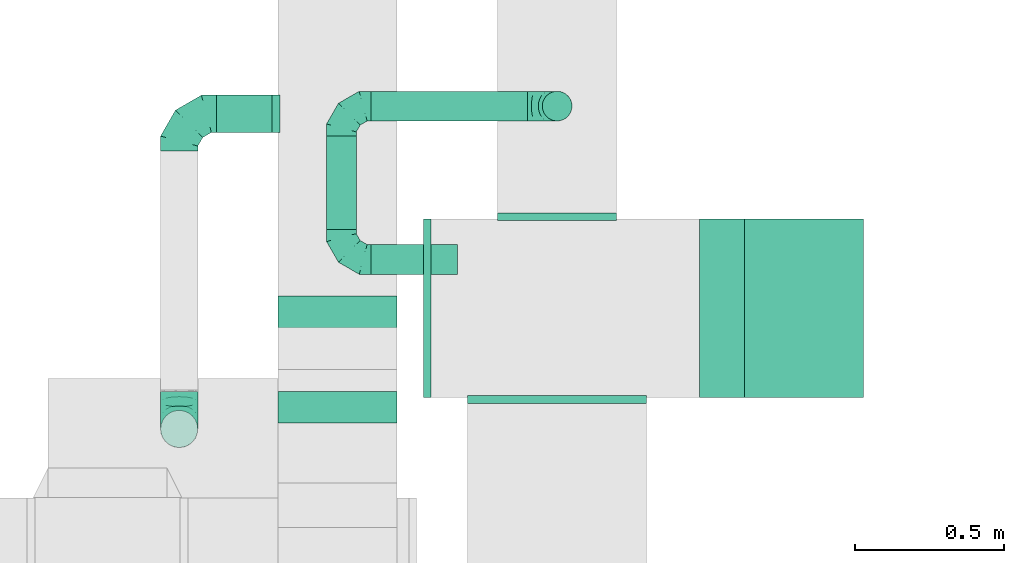
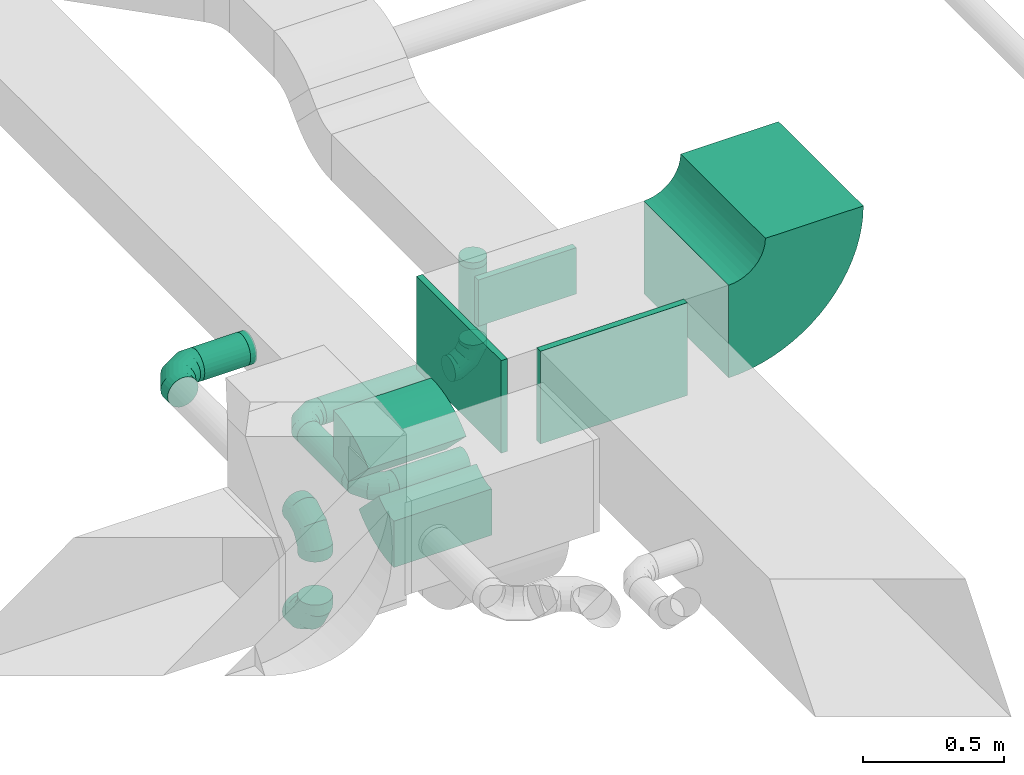
# One storey, part 33 of 60: 14 flow fittings, 5 flow segments.
"""IFC2X3 building model written with IfcOpenShell, lengths in millimetres."""

from ifc_helpers import new_model, entity, si_unit, converted_unit, derived_unit, direction, frame, frame_2d, origin, origin_2d_with_axis, place, context, subcontext, project, spatial, polyline, circle_curve, parameter, trimmed, segment, composite_curve, rectangle, circle, outline, extrude, faceted_brep, source, transform, mapped, material, type_object, type_shapes, element, save


model = new_model("IFC2X3")

# Units and contexts
model_context = context("Model", 3, precision=0.01, world=origin(), true_north=direction((6.12303176911189e-17, 1.0)))
body_context = subcontext(model_context, "Body", "Model", "MODEL_VIEW")
ifc_project = project(units=[si_unit("LENGTHUNIT", "METRE", prefix="MILLI"), si_unit("AREAUNIT", "SQUARE_METRE"), si_unit("VOLUMEUNIT", "CUBIC_METRE"), converted_unit("PLANEANGLEUNIT", "DEGREE", entity("IfcRatioMeasure", 0.0174532925199433), si_unit("PLANEANGLEUNIT", "RADIAN"), dimensions=[0, 0, 0, 0, 0, 0, 0]), si_unit("MASSUNIT", "GRAM", prefix="KILO"), derived_unit("MASSDENSITYUNIT", [(si_unit("MASSUNIT", "GRAM", prefix="KILO"), 1), (si_unit("LENGTHUNIT", "METRE"), -3)]), derived_unit("MOMENTOFINERTIAUNIT", [(si_unit("LENGTHUNIT", "METRE"), 4)]), si_unit("TIMEUNIT", "SECOND"), si_unit("FREQUENCYUNIT", "HERTZ"), si_unit("THERMODYNAMICTEMPERATUREUNIT", "DEGREE_CELSIUS"), derived_unit("THERMALTRANSMITTANCEUNIT", [(si_unit("MASSUNIT", "GRAM", prefix="KILO"), 1), (si_unit("THERMODYNAMICTEMPERATUREUNIT", "KELVIN"), -1), (si_unit("TIMEUNIT", "SECOND"), -3)]), derived_unit("VOLUMETRICFLOWRATEUNIT", [(si_unit("LENGTHUNIT", "METRE"), 3), (si_unit("TIMEUNIT", "SECOND"), -1)]), derived_unit("MASSFLOWRATEUNIT", [(si_unit("MASSUNIT", "GRAM", prefix="KILO"), 1), (si_unit("TIMEUNIT", "SECOND"), -1)]), derived_unit("ROTATIONALFREQUENCYUNIT", [(si_unit("TIMEUNIT", "SECOND"), -1)]), si_unit("ELECTRICCURRENTUNIT", "AMPERE"), si_unit("ELECTRICVOLTAGEUNIT", "VOLT"), si_unit("POWERUNIT", "WATT"), si_unit("FORCEUNIT", "NEWTON", prefix="KILO"), si_unit("ILLUMINANCEUNIT", "LUX"), si_unit("LUMINOUSFLUXUNIT", "LUMEN"), si_unit("LUMINOUSINTENSITYUNIT", "CANDELA"), derived_unit("USERDEFINED", [(si_unit("MASSUNIT", "GRAM", prefix="KILO"), -1), (si_unit("LENGTHUNIT", "METRE"), -2), (si_unit("TIMEUNIT", "SECOND"), 3), (si_unit("LUMINOUSFLUXUNIT", "LUMEN"), 1)]), derived_unit("LINEARVELOCITYUNIT", [(si_unit("LENGTHUNIT", "METRE"), 1), (si_unit("TIMEUNIT", "SECOND"), -1)]), si_unit("PRESSUREUNIT", "PASCAL"), derived_unit("USERDEFINED", [(si_unit("LENGTHUNIT", "METRE"), -2), (si_unit("MASSUNIT", "GRAM", prefix="KILO"), 1), (si_unit("TIMEUNIT", "SECOND"), -2)]), derived_unit("LINEARFORCEUNIT", [(si_unit("MASSUNIT", "GRAM", prefix="KILO"), 1), (si_unit("LENGTHUNIT", "METRE"), 1), (si_unit("TIMEUNIT", "SECOND"), -2), (si_unit("LENGTHUNIT", "METRE"), -1)]), derived_unit("PLANARFORCEUNIT", [(si_unit("MASSUNIT", "GRAM", prefix="KILO"), 1), (si_unit("LENGTHUNIT", "METRE"), 1), (si_unit("TIMEUNIT", "SECOND"), -2), (si_unit("LENGTHUNIT", "METRE"), -2)])], contexts=[model_context])

# Site, building, storey
site_placement = place(None, origin())
site = spatial("IfcSite", under=ifc_project, at=site_placement, CompositionType="ELEMENT")
building_placement = place(site_placement, origin())
building = spatial("IfcBuilding", under=site, at=building_placement, CompositionType="ELEMENT")
storey_placement = place(building_placement, frame((0.0, 0.0, 19800.0)))
storey = spatial("IfcBuildingStorey", under=building, at=storey_placement, CompositionType="ELEMENT", Elevation=19800.0)

# Flow segments
duct_segment_type = type_object("IfcDuctSegmentType", PredefinedType="NOTDEFINED")
flow_segment_1_placement = place(storey_placement, frame((42646.17, 13625.78, 3235.9)))
element("IfcFlowSegment", 1, at=flow_segment_1_placement, inside=storey, type_object=duct_segment_type, context=body_context, shape_type="SweptSolid", body=[
    extrude(circle(Radius=62.5, at=origin_2d_with_axis()), frame((0.0, 64.1, 64.1), z_axis=(1.0, 0.0, 0.0), x_axis=(0.0, 1.0, 0.0)), (0.0, 0.0, 1.0), 187.499999999983),
])
flow_segment_2_placement = place(storey_placement, frame((43739.71, 13664.1, 3000.0)))
element("IfcFlowSegment", 2, at=flow_segment_2_placement, inside=storey, type_object=duct_segment_type, context=body_context, shape_type="SweptSolid", body=[
    extrude(circle(Radius=50.0, at=origin_2d_with_axis()), frame((51.6, 51.6, 0.0)), (0.0, 0.0, 1.0), 329.999999999986),
])
flow_segment_3_placement = place(storey_placement, frame((43166.3, 13664.1, 2848.4)))
element("IfcFlowSegment", 3, at=flow_segment_3_placement, inside=storey, type_object=duct_segment_type, context=body_context, shape_type="SweptSolid", body=[
    extrude(circle(Radius=50.0, at=origin_2d_with_axis()), frame((0.0, 51.6, 51.6), z_axis=(1.0, 0.0, 0.0), x_axis=(0.0, 1.0, 0.0)), (0.0, 0.0, 1.0), 524.999999999985),
])
flow_segment_4_placement = place(storey_placement, frame((43014.71, 13300.7, 2848.4)))
element("IfcFlowSegment", 4, at=flow_segment_4_placement, inside=storey, type_object=duct_segment_type, context=body_context, shape_type="SweptSolid", body=[
    extrude(circle(Radius=50.0, at=origin_2d_with_axis()), frame((51.6, 0.0, 51.6), z_axis=(0.0, 1.0, 0.0), x_axis=(-1.0, 0.0, 0.0)), (0.0, 0.0, 1.0), 314.999999999998),
])
flow_segment_5_placement = place(storey_placement, frame((43166.3, 13149.1, 2848.4)))
element("IfcFlowSegment", 5, at=flow_segment_5_placement, inside=storey, type_object=duct_segment_type, context=body_context, shape_type="SweptSolid", body=[
    extrude(circle(Radius=50.0, at=origin_2d_with_axis()), frame((0.0, 51.6, 51.6), z_axis=(1.0, 0.0, 0.0), x_axis=(0.0, -1.0, 0.0)), (0.0, 0.0, 1.0), 289.999999999977),
])

# Flow fittings
ifc_material = material()
duct_fitting_type_1 = type_object("IfcDuctFittingType", PredefinedType="NOTDEFINED", material=ifc_material)
shared_shape_1 = source(origin(), body_context, "Body", "SweptSolid", [
    extrude(rectangle(XDim=26.0960000000006, YDim=400.0, at=origin_2d_with_axis()), frame((6.95, 0.0, -100.0)), (0.0, 0.0, 1.0), 200.0),
])
type_shapes(duct_fitting_type_1, [shared_shape_1])
flow_fitting_1_placement = place(storey_placement, frame((43791.3, 13337.27, 3450.0), z_axis=(0.0, 0.0, -1.0), x_axis=(0.0, 1.0, 0.0)))
element("IfcFlowFitting", 6, at=flow_fitting_1_placement, inside=storey, type_object=duct_fitting_type_1, material=ifc_material, context=body_context, shape_type="MappedRepresentation", body=[
    mapped(shared_shape_1, transform((0.0, 0.0, 0.0), scale=1.0)),
])
duct_fitting_type_2 = type_object("IfcDuctFittingType", PredefinedType="NOTDEFINED", material=ifc_material)
shared_shape_2 = source(origin(), body_context, "Body", "SweptSolid", [
    extrude(rectangle(XDim=24.9999999999999, YDim=600.0, at=origin_2d_with_axis()), frame((12.5, 0.0, -200.0)), (0.0, 0.0, 1.0), 400.0),
])
type_shapes(duct_fitting_type_2, [shared_shape_2])
flow_fitting_2_placement = place(storey_placement, frame((43366.87, 13037.27, 3450.0), z_axis=(0.0, 0.0, 1.0), x_axis=(-1.0, 0.0, 0.0)))
element("IfcFlowFitting", 7, at=flow_fitting_2_placement, inside=storey, type_object=duct_fitting_type_2, material=ifc_material, context=body_context, shape_type="MappedRepresentation", body=[
    mapped(shared_shape_2, transform((0.0, 0.0, 0.0), scale=1.0)),
])
duct_fitting_type_3 = type_object("IfcDuctFittingType", PredefinedType="NOTDEFINED", material=ifc_material)
shared_shape_3 = source(origin(), body_context, "Body", "SweptSolid", [
    extrude(rectangle(XDim=600.0, YDim=26.096000000013, at=origin_2d_with_axis()), frame((6.95, 0.0, -200.0), z_axis=(0.0, 0.0, 1.0), x_axis=(0.0, -1.0, 0.0)), (0.0, 0.0, 1.0), 400.0),
])
type_shapes(duct_fitting_type_3, [shared_shape_3])
flow_fitting_3_placement = place(storey_placement, frame((43790.59, 12737.27, 3450.0), z_axis=(0.0, 0.0, -1.0), x_axis=(0.0, -1.0, 0.0)))
element("IfcFlowFitting", 8, at=flow_fitting_3_placement, inside=storey, type_object=duct_fitting_type_3, material=ifc_material, context=body_context, shape_type="MappedRepresentation", body=[
    mapped(shared_shape_3, transform((0.0, 0.0, 0.0), scale=1.0)),
])
duct_fitting_type_4 = type_object("IfcDuctFittingType", PredefinedType="NOTDEFINED", material=ifc_material)
shared_shape_4 = source(origin(), body_context, "Body", "Brep", [
    faceted_brep([(-100.0, 0.0, -50.0), (-100.0, -12.94, -48.3), (-100.0, -25.0, -43.3), (-100.0, -35.36, -35.36), (-100.0, -43.3, -25.0), (-100.0, -48.3, -12.94), (-100.0, -50.0, 0.0), (-100.0, -48.3, 12.94), (-100.0, -43.3, 25.0), (-100.0, -35.36, 35.36), (-100.0, -25.0, 43.3), (-100.0, -12.94, 48.3), (-100.0, 0.0, 50.0), (-100.0, 12.94, 48.3), (-100.0, 25.0, 43.3), (-100.0, 35.36, 35.36), (-100.0, 43.3, 25.0), (-100.0, 48.3, 12.94), (-100.0, 50.0, 0.0), (-100.0, 48.3, -12.94), (-100.0, 43.3, -25.0), (-100.0, 35.36, -35.36), (-100.0, 25.0, -43.3), (-100.0, 12.94, -48.3), (-76.67, 12.94, 48.3), (-79.9, 25.0, 43.3), (-73.21, 0.0, 50.0), (-82.68, 35.36, 35.36), (-86.15, 48.3, 12.94), (-86.6, 50.0, 0.0), (-84.81, 43.3, 25.0), (-84.81, 43.3, -25.0), (-82.68, 35.36, -35.36), (-86.15, 48.3, -12.94), (-76.67, 12.94, -48.3), (-73.21, 0.0, -50.0), (-79.9, 25.0, -43.3), (-69.74, -12.94, -48.3), (-66.51, -25.0, -43.3), (-63.73, -35.36, -35.36), (-61.6, -43.3, -25.0), (-60.26, -48.3, -12.94), (-59.81, -50.0, 0.0), (-60.26, -48.3, 12.94), (-61.6, -43.3, 25.0), (-63.73, -35.36, 35.36), (-66.51, -25.0, 43.3), (-69.74, -12.94, 48.3), (-36.27, 36.27, 48.3), (-45.1, 45.1, 43.3), (-26.79, 26.79, 50.0), (-52.68, 52.68, 35.36), (-58.49, 58.49, 25.0), (-62.15, 62.15, 12.94), (-63.4, 63.4, 0.0), (-62.15, 62.15, -12.94), (-58.49, 58.49, -25.0), (-52.68, 52.68, -35.36), (-36.27, 36.27, -48.3), (-26.79, 26.79, -50.0), (-45.1, 45.1, -43.3), (-17.32, 17.32, -48.3), (-8.49, 8.49, -43.3), (-0.91, 0.91, -35.36), (4.9, -4.9, -25.0), (8.56, -8.56, -12.94), (9.81, -9.81, 0.0), (8.56, -8.56, 12.94), (4.9, -4.9, 25.0), (-0.91, 0.91, 35.36), (-8.49, 8.49, 43.3), (-17.32, 17.32, 48.3), (-12.94, 76.67, 48.3), (-25.0, 79.9, 43.3), (0.0, 73.21, 50.0), (-35.36, 82.68, 35.36), (-43.3, 84.81, 25.0), (-48.3, 86.15, 12.94), (-50.0, 86.6, 0.0), (-48.3, 86.15, -12.94), (-43.3, 84.81, -25.0), (-35.36, 82.68, -35.36), (-12.94, 76.67, -48.3), (0.0, 73.21, -50.0), (-25.0, 79.9, -43.3), (12.94, 69.74, -48.3), (25.0, 66.51, -43.3), (35.36, 63.73, -35.36), (43.3, 61.6, -25.0), (48.3, 60.26, -12.94), (50.0, 59.81, 0.0), (48.3, 60.26, 12.94), (43.3, 61.6, 25.0), (35.36, 63.73, 35.36), (25.0, 66.51, 43.3), (12.94, 69.74, 48.3), (-12.94, 100.0, -48.3), (-25.0, 100.0, -43.3), (-35.36, 100.0, -35.36), (-43.3, 100.0, -25.0), (-48.3, 100.0, -12.94), (-50.0, 100.0, 0.0), (-48.3, 100.0, 12.94), (-43.3, 100.0, 25.0), (-35.36, 100.0, 35.36), (-25.0, 100.0, 43.3), (-12.94, 100.0, 48.3), (0.0, 100.0, 50.0), (12.94, 100.0, 48.3), (25.0, 100.0, 43.3), (35.36, 100.0, 35.36), (43.3, 100.0, 25.0), (48.3, 100.0, 12.94), (50.0, 100.0, 0.0), (48.3, 100.0, -12.94), (43.3, 100.0, -25.0), (35.36, 100.0, -35.36), (25.0, 100.0, -43.3), (12.94, 100.0, -48.3), (0.0, 100.0, -50.0)], [[[0, 1, 2, 3, 4, 5, 6, 7, 8, 9, 10, 11, 12, 13, 14, 15, 16, 17, 18, 19, 20, 21, 22, 23]], [[24, 25, 14, 13]], [[26, 24, 13, 12]], [[14, 25, 27, 15]], [[28, 29, 18, 17]], [[30, 28, 17, 16]], [[15, 27, 30, 16]], [[20, 31, 32, 21]], [[33, 31, 20, 19]], [[18, 29, 33, 19]], [[34, 35, 0, 23]], [[36, 34, 23, 22]], [[32, 36, 22, 21]], [[2, 1, 37, 38]], [[3, 2, 38, 39]], [[0, 35, 37, 1]], [[5, 4, 40, 41]], [[6, 5, 41, 42]], [[3, 39, 40, 4]], [[6, 42, 43, 7]], [[7, 43, 44, 8]], [[8, 44, 45, 9]], [[10, 46, 47, 11]], [[11, 47, 26, 12]], [[10, 9, 45, 46]], [[48, 49, 25, 24]], [[50, 48, 24, 26]], [[27, 25, 49, 51]], [[52, 53, 28, 30]], [[51, 52, 30, 27]], [[29, 28, 53, 54]], [[55, 56, 31, 33]], [[54, 55, 33, 29]], [[57, 32, 31, 56]], [[58, 59, 35, 34]], [[60, 58, 34, 36]], [[57, 60, 36, 32]], [[37, 35, 59, 61]], [[38, 37, 61, 62]], [[39, 38, 62, 63]], [[41, 40, 64, 65]], [[42, 41, 65, 66]], [[63, 64, 40, 39]], [[43, 42, 66, 67]], [[44, 43, 67, 68]], [[68, 69, 45, 44]], [[46, 45, 69, 70]], [[47, 46, 70, 71]], [[26, 47, 71, 50]], [[72, 73, 49, 48]], [[74, 72, 48, 50]], [[51, 49, 73, 75]], [[76, 77, 53, 52]], [[75, 76, 52, 51]], [[54, 53, 77, 78]], [[79, 80, 56, 55]], [[78, 79, 55, 54]], [[81, 57, 56, 80]], [[82, 83, 59, 58]], [[84, 82, 58, 60]], [[81, 84, 60, 57]], [[61, 59, 83, 85]], [[62, 61, 85, 86]], [[63, 62, 86, 87]], [[65, 64, 88, 89]], [[66, 65, 89, 90]], [[87, 88, 64, 63]], [[67, 66, 90, 91]], [[68, 67, 91, 92]], [[92, 93, 69, 68]], [[70, 69, 93, 94]], [[71, 70, 94, 95]], [[50, 71, 95, 74]], [[96, 97, 98, 99, 100, 101, 102, 103, 104, 105, 106, 107, 108, 109, 110, 111, 112, 113, 114, 115, 116, 117, 118, 119]], [[72, 74, 107, 106]], [[73, 72, 106, 105]], [[75, 73, 105, 104]], [[77, 76, 103, 102]], [[78, 77, 102, 101]], [[75, 104, 103, 76]], [[78, 101, 100, 79]], [[79, 100, 99, 80]], [[80, 99, 98, 81]], [[96, 119, 83, 82]], [[97, 96, 82, 84]], [[84, 81, 98, 97]], [[83, 119, 118, 85]], [[85, 118, 117, 86]], [[86, 117, 116, 87]], [[88, 115, 114, 89]], [[89, 114, 113, 90]], [[87, 116, 115, 88]], [[91, 90, 113, 112]], [[92, 91, 112, 111]], [[93, 92, 111, 110]], [[95, 94, 109, 108]], [[74, 95, 108, 107]], [[110, 109, 94, 93]]]),
])
type_shapes(duct_fitting_type_4, [shared_shape_4])
for number, where, z_axis, x_axis in (
    (9, (43791.3, 13715.7, 2900.0), (0.0, 1.0, 0.0), (0.0, 0.0, -1.0)),
    (10, (43066.3, 13715.7, 2900.0), (0.0, 0.0, 1.0), (-1.0, 0.0, 0.0)),
    (11, (43066.3, 13200.7, 2900.0), (0.0, 0.0, 1.0), (0.0, -1.0, 0.0)),
):
    element("IfcFlowFitting", number, at=place(storey_placement, frame(where, z_axis=z_axis, x_axis=x_axis)), inside=storey, type_object=duct_fitting_type_4, material=ifc_material, context=body_context, shape_type="MappedRepresentation", body=[
        mapped(shared_shape_4, transform((0.0, 0.0, 0.0), scale=1.0)),
    ])
duct_fitting_type_5 = type_object("IfcDuctFittingType", PredefinedType="NOTDEFINED", material=ifc_material)
shared_shape_5 = source(origin(), body_context, "Body", "Brep", [
    faceted_brep([(-125.0, 0.0, -62.5), (-125.0, -16.18, -60.37), (-125.0, -31.25, -54.13), (-125.0, -44.19, -44.19), (-125.0, -54.13, -31.25), (-125.0, -60.37, -16.18), (-125.0, -62.5, 0.0), (-125.0, -60.37, 16.18), (-125.0, -54.13, 31.25), (-125.0, -44.19, 44.19), (-125.0, -31.25, 54.13), (-125.0, -16.18, 60.37), (-125.0, 0.0, 62.5), (-125.0, 16.18, 60.37), (-125.0, 31.25, 54.13), (-125.0, 44.19, 44.19), (-125.0, 54.13, 31.25), (-125.0, 60.37, 16.18), (-125.0, 62.5, 0.0), (-125.0, 60.37, -16.18), (-125.0, 54.13, -31.25), (-125.0, 44.19, -44.19), (-125.0, 31.25, -54.13), (-125.0, 16.18, -60.37), (-95.84, 16.18, 60.37), (-99.88, 31.25, 54.13), (-91.51, 0.0, 62.5), (-103.35, 44.19, 44.19), (-107.68, 60.37, 16.18), (-108.25, 62.5, 0.0), (-106.01, 54.13, 31.25), (-106.01, 54.13, -31.25), (-103.35, 44.19, -44.19), (-107.68, 60.37, -16.18), (-95.84, 16.18, -60.37), (-91.51, 0.0, -62.5), (-99.88, 31.25, -54.13), (-87.17, -16.18, -60.37), (-83.13, -31.25, -54.13), (-79.66, -44.19, -44.19), (-77.0, -54.13, -31.25), (-75.33, -60.37, -16.18), (-74.76, -62.5, 0.0), (-75.33, -60.37, 16.18), (-77.0, -54.13, 31.25), (-79.66, -44.19, 44.19), (-83.13, -31.25, 54.13), (-87.17, -16.18, 60.37), (-45.34, 45.34, 60.37), (-56.37, 56.37, 54.13), (-33.49, 33.49, 62.5), (-65.85, 65.85, 44.19), (-73.12, 73.12, 31.25), (-77.69, 77.69, 16.18), (-79.25, 79.25, 0.0), (-77.69, 77.69, -16.18), (-73.12, 73.12, -31.25), (-65.85, 65.85, -44.19), (-45.34, 45.34, -60.37), (-33.49, 33.49, -62.5), (-56.37, 56.37, -54.13), (-21.65, 21.65, -60.37), (-10.62, 10.62, -54.13), (-1.14, 1.14, -44.19), (6.13, -6.13, -31.25), (10.7, -10.7, -16.18), (12.26, -12.26, 0.0), (10.7, -10.7, 16.18), (6.13, -6.13, 31.25), (-1.14, 1.14, 44.19), (-10.62, 10.62, 54.13), (-21.65, 21.65, 60.37), (-16.18, 95.84, 60.37), (-31.25, 99.88, 54.13), (0.0, 91.51, 62.5), (-44.19, 103.35, 44.19), (-54.13, 106.01, 31.25), (-60.37, 107.68, 16.18), (-62.5, 108.25, 0.0), (-60.37, 107.68, -16.18), (-54.13, 106.01, -31.25), (-44.19, 103.35, -44.19), (-16.18, 95.84, -60.37), (0.0, 91.51, -62.5), (-31.25, 99.88, -54.13), (16.18, 87.17, -60.37), (31.25, 83.13, -54.13), (44.19, 79.66, -44.19), (54.13, 77.0, -31.25), (60.37, 75.33, -16.18), (62.5, 74.76, 0.0), (60.37, 75.33, 16.18), (54.13, 77.0, 31.25), (44.19, 79.66, 44.19), (31.25, 83.13, 54.13), (16.18, 87.17, 60.37), (-16.18, 125.0, -60.37), (-31.25, 125.0, -54.13), (-44.19, 125.0, -44.19), (-54.13, 125.0, -31.25), (-60.37, 125.0, -16.18), (-62.5, 125.0, 0.0), (-60.37, 125.0, 16.18), (-54.13, 125.0, 31.25), (-44.19, 125.0, 44.19), (-31.25, 125.0, 54.13), (-16.18, 125.0, 60.37), (0.0, 125.0, 62.5), (16.18, 125.0, 60.37), (31.25, 125.0, 54.13), (44.19, 125.0, 44.19), (54.13, 125.0, 31.25), (60.37, 125.0, 16.18), (62.5, 125.0, 0.0), (60.37, 125.0, -16.18), (54.13, 125.0, -31.25), (44.19, 125.0, -44.19), (31.25, 125.0, -54.13), (16.18, 125.0, -60.37), (0.0, 125.0, -62.5)], [[[0, 1, 2, 3, 4, 5, 6, 7, 8, 9, 10, 11, 12, 13, 14, 15, 16, 17, 18, 19, 20, 21, 22, 23]], [[24, 25, 14, 13]], [[26, 24, 13, 12]], [[14, 25, 27, 15]], [[28, 29, 18, 17]], [[30, 28, 17, 16]], [[15, 27, 30, 16]], [[20, 31, 32, 21]], [[33, 31, 20, 19]], [[18, 29, 33, 19]], [[34, 35, 0, 23]], [[36, 34, 23, 22]], [[21, 32, 36, 22]], [[1, 0, 35, 37]], [[2, 1, 37, 38]], [[38, 39, 3, 2]], [[5, 4, 40, 41]], [[6, 5, 41, 42]], [[39, 40, 4, 3]], [[6, 42, 43, 7]], [[7, 43, 44, 8]], [[45, 9, 8, 44]], [[9, 45, 46, 10]], [[10, 46, 47, 11]], [[26, 12, 11, 47]], [[48, 49, 25, 24]], [[50, 48, 24, 26]], [[27, 25, 49, 51]], [[52, 53, 28, 30]], [[51, 52, 30, 27]], [[29, 28, 53, 54]], [[55, 56, 31, 33]], [[54, 55, 33, 29]], [[57, 32, 31, 56]], [[58, 59, 35, 34]], [[60, 58, 34, 36]], [[57, 60, 36, 32]], [[37, 35, 59, 61]], [[38, 37, 61, 62]], [[39, 38, 62, 63]], [[41, 40, 64, 65]], [[42, 41, 65, 66]], [[63, 64, 40, 39]], [[43, 42, 66, 67]], [[44, 43, 67, 68]], [[68, 69, 45, 44]], [[46, 45, 69, 70]], [[47, 46, 70, 71]], [[26, 47, 71, 50]], [[72, 73, 49, 48]], [[74, 72, 48, 50]], [[51, 49, 73, 75]], [[76, 77, 53, 52]], [[75, 76, 52, 51]], [[54, 53, 77, 78]], [[79, 80, 56, 55]], [[78, 79, 55, 54]], [[81, 57, 56, 80]], [[82, 83, 59, 58]], [[84, 82, 58, 60]], [[81, 84, 60, 57]], [[61, 59, 83, 85]], [[62, 61, 85, 86]], [[63, 62, 86, 87]], [[65, 64, 88, 89]], [[66, 65, 89, 90]], [[87, 88, 64, 63]], [[67, 66, 90, 91]], [[68, 67, 91, 92]], [[92, 93, 69, 68]], [[70, 69, 93, 94]], [[71, 70, 94, 95]], [[50, 71, 95, 74]], [[96, 97, 98, 99, 100, 101, 102, 103, 104, 105, 106, 107, 108, 109, 110, 111, 112, 113, 114, 115, 116, 117, 118, 119]], [[72, 74, 107, 106]], [[73, 72, 106, 105]], [[75, 73, 105, 104]], [[77, 76, 103, 102]], [[78, 77, 102, 101]], [[75, 104, 103, 76]], [[78, 101, 100, 79]], [[79, 100, 99, 80]], [[80, 99, 98, 81]], [[96, 119, 83, 82]], [[97, 96, 82, 84]], [[84, 81, 98, 97]], [[83, 119, 118, 85]], [[85, 118, 117, 86]], [[116, 87, 86, 117]], [[88, 115, 114, 89]], [[89, 114, 113, 90]], [[115, 88, 87, 116]], [[91, 90, 113, 112]], [[92, 91, 112, 111]], [[111, 110, 93, 92]], [[95, 94, 109, 108]], [[74, 95, 108, 107]], [[110, 109, 94, 93]]]),
])
type_shapes(duct_fitting_type_5, [shared_shape_5])
for number, where, z_axis, x_axis in (
    (12, (42521.17, 13689.87, 3300.0), (0.0, 0.0, 1.0), (-1.0, 0.0, 0.0)),
    (13, (42521.17, 12631.12, 3300.0), (1.0, 0.0, 0.0), (0.0, -1.0, 0.0)),
    (14, (42521.17, 12631.12, 2865.0), (1.0, 0.0, 0.0), (0.0, 0.0, -1.0)),
):
    element("IfcFlowFitting", number, at=place(storey_placement, frame(where, z_axis=z_axis, x_axis=x_axis)), inside=storey, type_object=duct_fitting_type_5, material=ifc_material, context=body_context, shape_type="MappedRepresentation", body=[
        mapped(shared_shape_5, transform((0.0, 0.0, 0.0), scale=1.0)),
    ])
duct_fitting_type_6 = type_object("IfcDuctFittingType", PredefinedType="NOTDEFINED", material=ifc_material)
shared_shape_6 = source(origin(), body_context, "Body", "Brep", [
    faceted_brep([(20.0, 0.0, -62.5), (20.0, 16.18, -60.37), (20.0, 31.25, -54.13), (20.0, 44.19, -44.19), (20.0, 54.13, -31.25), (20.0, 60.37, -16.18), (20.0, 62.5, 0.0), (20.0, 60.37, 16.18), (20.0, 54.13, 31.25), (20.0, 44.19, 44.19), (20.0, 31.25, 54.13), (20.0, 16.18, 60.37), (20.0, 0.0, 62.5), (20.0, -16.18, 60.37), (20.0, -31.25, 54.13), (20.0, -44.19, 44.19), (20.0, -54.13, 31.25), (20.0, -60.37, 16.18), (20.0, -62.5, 0.0), (20.0, -60.37, -16.18), (20.0, -54.13, -31.25), (20.0, -44.19, -44.19), (20.0, -31.25, -54.13), (20.0, -16.18, -60.37), (0.0, 0.0, 62.5), (-6.1, 0.0, 62.5), (-6.1, -16.18, 60.37), (0.0, -16.18, 60.37), (-6.1, -31.25, 54.13), (0.0, -31.25, 54.13), (0.0, -44.19, 44.19), (-6.1, -44.19, 44.19), (0.0, -54.13, 31.25), (-6.1, -54.13, 31.25), (-6.1, -60.37, 16.18), (0.0, -60.37, 16.18), (-6.1, -62.5, 0.0), (0.0, -62.5, 0.0), (-6.1, -60.37, -16.18), (0.0, -60.37, -16.18), (-6.1, -54.13, -31.25), (0.0, -54.13, -31.25), (0.0, -44.19, -44.19), (-6.1, -44.19, -44.19), (0.0, -31.25, -54.13), (-6.1, -31.25, -54.13), (-6.1, -16.18, -60.37), (0.0, -16.18, -60.37), (-6.1, 0.0, -62.5), (0.0, 0.0, -62.5), (-6.1, 16.18, -60.37), (0.0, 16.18, -60.37), (-6.1, 31.25, -54.13), (0.0, 31.25, -54.13), (0.0, 44.19, -44.19), (-6.1, 44.19, -44.19), (0.0, 54.13, -31.25), (-6.1, 54.13, -31.25), (-6.1, 60.37, -16.18), (0.0, 60.37, -16.18), (-6.1, 62.5, 0.0), (0.0, 62.5, 0.0), (-6.1, 60.37, 16.18), (0.0, 60.37, 16.18), (-6.1, 54.13, 31.25), (0.0, 54.13, 31.25), (0.0, 44.19, 44.19), (-6.1, 44.19, 44.19), (0.0, 31.25, 54.13), (-6.1, 31.25, 54.13), (-6.1, 16.18, 60.37), (0.0, 16.18, 60.37)], [[[0, 1, 2, 3, 4, 5, 6, 7, 8, 9, 10, 11, 12, 13, 14, 15, 16, 17, 18, 19, 20, 21, 22, 23]], [[13, 12, 24, 25, 26, 27]], [[14, 13, 27, 26, 28, 29]], [[30, 15, 14, 29, 28, 31]], [[17, 16, 32, 33, 34, 35]], [[18, 17, 35, 34, 36, 37]], [[32, 16, 15, 30, 31, 33]], [[19, 18, 37, 36, 38, 39]], [[20, 19, 39, 38, 40, 41]], [[42, 21, 20, 41, 40, 43]], [[23, 22, 44, 45, 46, 47]], [[0, 23, 47, 46, 48, 49]], [[44, 22, 21, 42, 43, 45]], [[1, 0, 49, 48, 50, 51]], [[2, 1, 51, 50, 52, 53]], [[54, 3, 2, 53, 52, 55]], [[5, 4, 56, 57, 58, 59]], [[6, 5, 59, 58, 60, 61]], [[56, 4, 3, 54, 55, 57]], [[7, 6, 61, 60, 62, 63]], [[8, 7, 63, 62, 64, 65]], [[66, 9, 8, 65, 64, 67]], [[11, 10, 68, 69, 70, 71]], [[12, 11, 71, 70, 25, 24]], [[68, 10, 9, 66, 67, 69]], [[46, 45, 43, 40, 38, 36, 34, 33, 31, 28, 26, 25, 70, 69, 67, 64, 62, 60, 58, 57, 55, 52, 50, 48]]]),
])
type_shapes(duct_fitting_type_6, [shared_shape_6])
flow_fitting_4_placement = place(storey_placement, frame((42853.67, 13689.87, 3300.0), z_axis=(0.0, 0.0, -1.0), x_axis=(-1.0, 0.0, 0.0)))
element("IfcFlowFitting", 15, at=flow_fitting_4_placement, inside=storey, type_object=duct_fitting_type_6, material=ifc_material, context=body_context, shape_type="MappedRepresentation", body=[
    mapped(shared_shape_6, transform((0.0, 0.0, 0.0), scale=1.0)),
])
duct_fitting_type_7 = type_object("IfcDuctFittingType", PredefinedType="NOTDEFINED", material=ifc_material)
shared_shape_7 = source(origin(), body_context, "Body", "Brep", [
    faceted_brep([(20.0, 0.0, -50.0), (20.0, 12.94, -48.3), (20.0, 25.0, -43.3), (20.0, 35.36, -35.36), (20.0, 43.3, -25.0), (20.0, 48.3, -12.94), (20.0, 50.0, 0.0), (20.0, 48.3, 12.94), (20.0, 43.3, 25.0), (20.0, 35.36, 35.36), (20.0, 25.0, 43.3), (20.0, 12.94, 48.3), (20.0, 0.0, 50.0), (20.0, -12.94, 48.3), (20.0, -25.0, 43.3), (20.0, -35.36, 35.36), (20.0, -43.3, 25.0), (20.0, -48.3, 12.94), (20.0, -50.0, 0.0), (20.0, -48.3, -12.94), (20.0, -43.3, -25.0), (20.0, -35.36, -35.36), (20.0, -25.0, -43.3), (20.0, -12.94, -48.3), (0.0, 0.0, 50.0), (-6.1, 0.0, 50.0), (-6.1, -12.94, 48.3), (0.0, -12.94, 48.3), (-6.1, -25.0, 43.3), (0.0, -25.0, 43.3), (0.0, -35.36, 35.36), (-6.1, -35.36, 35.36), (0.0, -43.3, 25.0), (-6.1, -43.3, 25.0), (-6.1, -48.3, 12.94), (0.0, -48.3, 12.94), (-6.1, -50.0, 0.0), (0.0, -50.0, 0.0), (-6.1, -48.3, -12.94), (0.0, -48.3, -12.94), (-6.1, -43.3, -25.0), (0.0, -43.3, -25.0), (0.0, -35.36, -35.36), (-6.1, -35.36, -35.36), (0.0, -25.0, -43.3), (-6.1, -25.0, -43.3), (-6.1, -12.94, -48.3), (0.0, -12.94, -48.3), (-6.1, 0.0, -50.0), (0.0, 0.0, -50.0), (-6.1, 12.94, -48.3), (0.0, 12.94, -48.3), (-6.1, 25.0, -43.3), (0.0, 25.0, -43.3), (0.0, 35.36, -35.36), (-6.1, 35.36, -35.36), (0.0, 43.3, -25.0), (-6.1, 43.3, -25.0), (-6.1, 48.3, -12.94), (0.0, 48.3, -12.94), (-6.1, 50.0, 0.0), (0.0, 50.0, 0.0), (-6.1, 48.3, 12.94), (0.0, 48.3, 12.94), (-6.1, 43.3, 25.0), (0.0, 43.3, 25.0), (0.0, 35.36, 35.36), (-6.1, 35.36, 35.36), (0.0, 25.0, 43.3), (-6.1, 25.0, 43.3), (-6.1, 12.94, 48.3), (0.0, 12.94, 48.3)], [[[0, 1, 2, 3, 4, 5, 6, 7, 8, 9, 10, 11, 12, 13, 14, 15, 16, 17, 18, 19, 20, 21, 22, 23]], [[13, 12, 24, 25, 26, 27]], [[14, 13, 27, 26, 28, 29]], [[30, 15, 14, 29, 28, 31]], [[17, 16, 32, 33, 34, 35]], [[18, 17, 35, 34, 36, 37]], [[32, 16, 15, 30, 31, 33]], [[19, 18, 37, 36, 38, 39]], [[20, 19, 39, 38, 40, 41]], [[42, 21, 20, 41, 40, 43]], [[23, 22, 44, 45, 46, 47]], [[0, 23, 47, 46, 48, 49]], [[44, 22, 21, 42, 43, 45]], [[1, 0, 49, 48, 50, 51]], [[2, 1, 51, 50, 52, 53]], [[54, 3, 2, 53, 52, 55]], [[5, 4, 56, 57, 58, 59]], [[6, 5, 59, 58, 60, 61]], [[56, 4, 3, 54, 55, 57]], [[7, 6, 61, 60, 62, 63]], [[8, 7, 63, 62, 64, 65]], [[66, 9, 8, 65, 64, 67]], [[11, 10, 68, 69, 70, 71]], [[12, 11, 71, 70, 25, 24]], [[68, 10, 9, 66, 67, 69]], [[46, 45, 43, 40, 38, 36, 34, 33, 31, 28, 26, 25, 70, 69, 67, 64, 62, 60, 58, 57, 55, 52, 50, 48]]]),
])
type_shapes(duct_fitting_type_7, [shared_shape_7])
flow_fitting_5_placement = place(storey_placement, frame((43791.3, 13715.7, 3350.0), z_axis=(0.0, -1.0, 0.0), x_axis=(0.0, 0.0, -1.0)))
element("IfcFlowFitting", 16, at=flow_fitting_5_placement, inside=storey, type_object=duct_fitting_type_7, material=ifc_material, context=body_context, shape_type="MappedRepresentation", body=[
    mapped(shared_shape_7, transform((0.0, 0.0, 0.0), scale=1.0)),
])
duct_fitting_type_8 = type_object("IfcDuctFittingType", PredefinedType="NOTDEFINED", material=ifc_material)
shared_shape_8 = source(origin(), body_context, "Body", "SweptSolid", [
    extrude(outline(composite_curve([segment(polyline([(-136.61, -88.39), (63.39, -88.39)]), True, "CONTINUOUS"), segment(trimmed(circle_curve(frame_2d((213.39, -88.39), x_axis=(-0.707106781186546, 0.707106781186546)), 150.0), [parameter(0.0)], [parameter(45.0)], True, "PARAMETER"), False, "CONTINUOUS"), segment(polyline([(107.32, 17.68), (-34.1, 159.1)]), True, "CONTINUOUS"), segment(trimmed(circle_curve(frame_2d((213.39, -88.39), x_axis=(-0.707106781186546, 0.707106781186546)), 350.0), [parameter(0.0)], [parameter(45.0)], True, "PARAMETER"), True, "CONTINUOUS")], self_intersect=False)), frame((-15.17, 36.61, -200.0), z_axis=(0.0, 0.0, 1.0), x_axis=(-0.707106781186547, 0.707106781186548, 0.0)), (0.0, 0.0, 1.0), 400.0),
])
type_shapes(duct_fitting_type_8, [shared_shape_8])
for number, where, z_axis, x_axis in (
    (17, (43053.67, 12754.48, 3080.0), (1.0, 0.0, 0.0), (0.0, 1.0, 0.0)),
    (18, (43053.67, 12974.48, 3300.0), (-1.0, 0.0, 0.0), (0.0, 0.707106781186503, 0.707106781186592)),
):
    element("IfcFlowFitting", number, at=place(storey_placement, frame(where, z_axis=z_axis, x_axis=x_axis)), inside=storey, type_object=duct_fitting_type_8, material=ifc_material, context=body_context, shape_type="MappedRepresentation", body=[
        mapped(shared_shape_8, transform((0.0, 0.0, 0.0), scale=1.0)),
    ])
duct_fitting_type_9 = type_object("IfcDuctFittingType", PredefinedType="NOTDEFINED", material=ifc_material)
shared_shape_9 = source(origin(), body_context, "Body", "SweptSolid", [
    extrude(outline(composite_curve([segment(polyline([(-375.0, -175.0), (25.0, -175.0)]), True, "CONTINUOUS"), segment(trimmed(circle_curve(frame_2d((175.0, -175.0), x_axis=(0.0, 1.0)), 150.0), [parameter(0.0)], [parameter(90.0000000000001)], True, "PARAMETER"), False, "CONTINUOUS"), segment(polyline([(175.0, -25.0), (175.0, 375.0)]), True, "CONTINUOUS"), segment(trimmed(circle_curve(frame_2d((175.0, -175.0), x_axis=(0.0, 1.0)), 550.0), [parameter(0.0)], [parameter(90.0)], True, "PARAMETER"), True, "CONTINUOUS")], self_intersect=False)), frame((-175.0, 175.0, -300.0), z_axis=(0.0, 0.0, 1.0), x_axis=(-1.0, 0.0, 0.0)), (0.0, 0.0, 1.0), 600.0),
])
type_shapes(duct_fitting_type_9, [shared_shape_9])
flow_fitting_6_placement = place(storey_placement, frame((44620.31, 13037.27, 3450.0), z_axis=(0.0, -1.0, 0.0), x_axis=(1.0, 0.0, 0.0)))
element("IfcFlowFitting", 19, at=flow_fitting_6_placement, inside=storey, type_object=duct_fitting_type_9, material=ifc_material, context=body_context, shape_type="MappedRepresentation", body=[
    mapped(shared_shape_9, transform((0.0, 0.0, 0.0), scale=1.0)),
])

save(model, "model.ifc")
